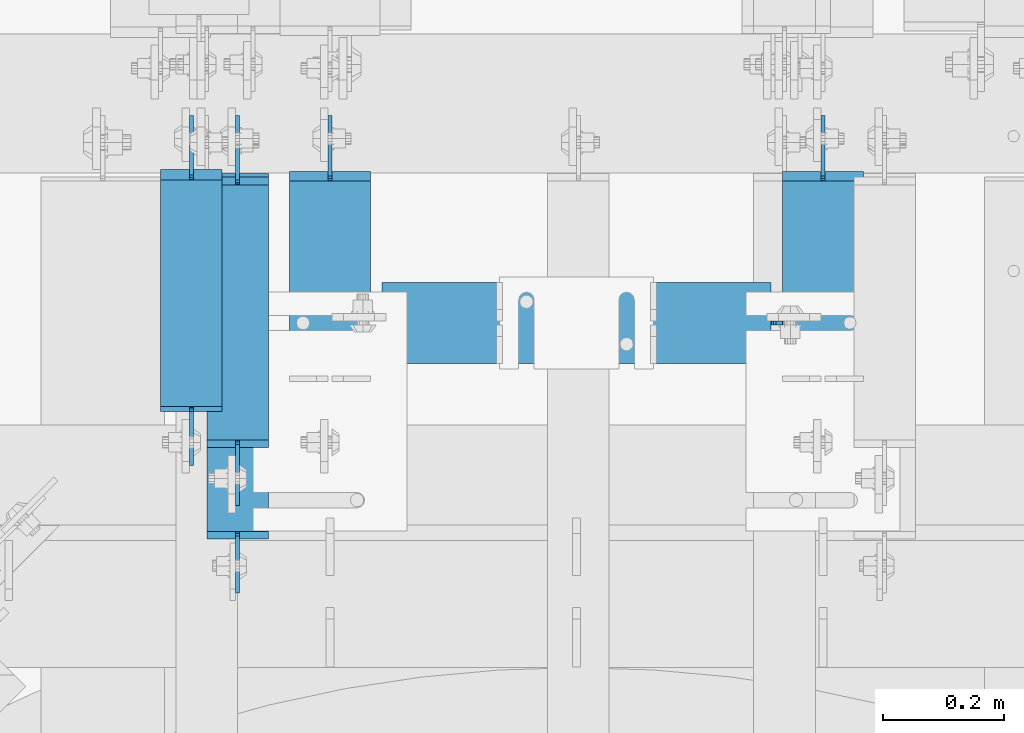
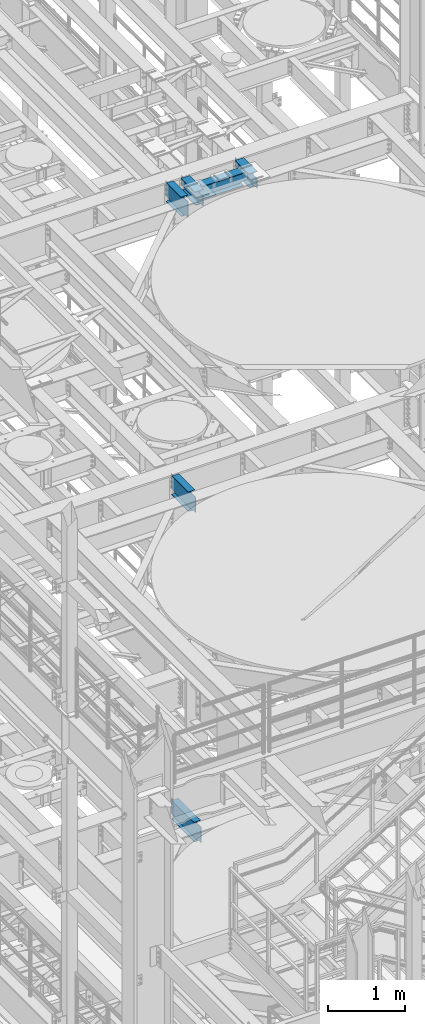
# One storey, part 1240 of 1876: 6 beams, 6 elements without a shape of their own.
"""IFC2X3 building model written with IfcOpenShell, lengths in millimetres."""

import ifcopenshell
import ifcopenshell.guid

model = None  # the IFC model being written
_history = None  # IfcOwnerHistory: only IFC2X3 demands one
_inside = {}  # id of a spatial element -> (the spatial element, [elements in it])
_under = {}  # id of a project, library or spatial element -> (it, [spatial elements below it])
_declared = {}  # id of a project -> (the project, [libraries it declares])
_typed = {}  # id of a type object -> (the type object, [elements of that type])
_made_of = {}  # id of a material, layer set ... -> (it, [elements and type objects made of it])


def new_model(schema):
    """Start an empty IFC model of exactly this schema.

    Asked for "IFC4X3", IfcOpenShell would pick the latest addendum, in which some entities
    have other attributes; the version numbers below select the first issue.
    IFC2X3 requires an IfcOwnerHistory on every rooted entity: one is made here for all.
    """
    global model, _history
    if schema == "IFC4X3":
        model = ifcopenshell.file(schema_version=(4, 3, 0, 0))
    else:
        model = ifcopenshell.file(schema=schema)
    _inside.clear()
    _under.clear()
    _declared.clear()
    _typed.clear()
    _made_of.clear()
    _history = None
    if model.schema == "IFC2X3":
        org = make("IfcOrganization", Name="unknown")
        user = make(
            "IfcPersonAndOrganization",
            ThePerson=make("IfcPerson", FamilyName="unknown"),
            TheOrganization=org,
        )
        app = make(
            "IfcApplication",
            ApplicationDeveloper=org,
            Version="unknown",
            ApplicationFullName="unknown",
            ApplicationIdentifier="unknown",
        )
        _history = make(
            "IfcOwnerHistory",
            OwningUser=user,
            OwningApplication=app,
            ChangeAction="ADDED",
            CreationDate=0,
        )
    return model


def make(cls, **values):
    """One entity of the class cls with the attributes given. An attribute that is None is left unset."""
    return model.create_entity(
        cls, **{name: value for name, value in values.items() if value is not None}
    )


def rooted(cls, **values):
    """An entity with a GlobalId (a new one), such as an element, a storey or a relation."""
    return make(cls, GlobalId=ifcopenshell.guid.new(), OwnerHistory=_history, **values)


def si_unit(unit_type, name, prefix=None):
    """IfcSIUnit, for example si_unit("LENGTHUNIT", "METRE", prefix="MILLI")."""
    return make("IfcSIUnit", UnitType=unit_type, Prefix=prefix, Name=name)


def assignment(units):
    """IfcUnitAssignment: the units of a project."""
    return None if units is None else make("IfcUnitAssignment", Units=units)


def point(xyz):
    """IfcCartesianPoint."""
    return None if xyz is None else make("IfcCartesianPoint", Coordinates=xyz)


def direction(xyz):
    """IfcDirection."""
    return None if xyz is None else make("IfcDirection", DirectionRatios=xyz)


def frame(location, z_axis=None, x_axis=None):
    """IfcAxis2Placement3D, a coordinate frame: its origin and axes. An axis left out is left unset."""
    return make(
        "IfcAxis2Placement3D",
        Location=point(location),
        Axis=direction(z_axis),
        RefDirection=direction(x_axis),
    )


def origin_with_axes():
    """The frame at (0, 0, 0) with the z axis (0, 0, 1) and the x axis (1, 0, 0) written out."""
    return frame((0.0, 0.0, 0.0), z_axis=(0.0, 0.0, 1.0), x_axis=(1.0, 0.0, 0.0))


def place(relative_to, where):
    """IfcLocalPlacement: puts the frame where relative to a parent placement (None: the world)."""
    return make(
        "IfcLocalPlacement", PlacementRelTo=relative_to, RelativePlacement=where
    )


def context(
    kind, dimensions, precision=None, world=None, true_north=None, identifier=None
):
    """IfcGeometricRepresentationContext, for example the 3D "Model" context."""
    return make(
        "IfcGeometricRepresentationContext",
        ContextIdentifier=identifier,
        ContextType=kind,
        CoordinateSpaceDimension=dimensions,
        Precision=precision,
        WorldCoordinateSystem=world,
        TrueNorth=true_north,
    )


def subcontext(parent, identifier, kind, view, scale=None):
    """IfcGeometricRepresentationSubContext, for example "Body" below "Model"."""
    return make(
        "IfcGeometricRepresentationSubContext",
        ContextIdentifier=identifier,
        ContextType=kind,
        ParentContext=parent,
        TargetScale=scale,
        TargetView=view,
    )


def project(units=None, contexts=None):
    """IfcProject with its units and contexts."""
    return rooted(
        "IfcProject",
        Name="project",
        RepresentationContexts=contexts,
        UnitsInContext=assignment(units),
    )


def spatial(cls, under=None, at=None, **own):
    """A site, building, storey or space (cls), placed at a placement, below another one or the project."""
    s = rooted(cls, ObjectPlacement=at, **own)
    if under is not None:
        _under.setdefault(under.id(), (under, []))[1].append(s)
    return s


def faces_of(points, faces, orient=None, outer=None):
    """IfcFace entities. A face is a list of loops; a loop is a list of indices into points, from 0.

    orient and outer hold one flag for each loop. By default every Orientation is true, the
    first loop of a face is its IfcFaceOuterBound and the others are IfcFaceBound.
    """
    made = []
    for i, loops in enumerate(faces):
        bounds = []
        for j, loop in enumerate(loops):
            is_outer = j == 0 if outer is None else outer[i][j]
            bounds.append(
                make(
                    "IfcFaceOuterBound" if is_outer else "IfcFaceBound",
                    Bound=make("IfcPolyLoop", Polygon=[points[k] for k in loop]),
                    Orientation=True if orient is None else orient[i][j],
                )
            )
        made.append(make("IfcFace", Bounds=bounds))
    return made


def faceted_brep(points, faces, orient=None, outer=None, voids=None):
    """IfcFacetedBrep: a solid bounded by flat faces; with voids (closed shells), ...WithVoids."""
    shared = [point(p) for p in points]
    hull = make("IfcClosedShell", CfsFaces=faces_of(shared, faces, orient, outer))
    if voids is None:
        return make("IfcFacetedBrep", Outer=hull)
    return make(
        "IfcFacetedBrepWithVoids",
        Outer=hull,
        Voids=[
            make(cls, CfsFaces=faces_of(shared, fs, o, b)) for cls, fs, o, b in voids
        ],
    )


def shape(context_of_items, identifier, shape_type, items):
    """IfcShapeRepresentation: the items that make up one representation, for example the "Body"."""
    return make(
        "IfcShapeRepresentation",
        ContextOfItems=context_of_items,
        RepresentationIdentifier=identifier,
        RepresentationType=shape_type,
        Items=items,
    )


def material(Name=None, Category=None):
    """IfcMaterial."""
    return make("IfcMaterial", Name=Name, Category=Category)


def made_of(thing, what):
    """Note that an element or type object is made of a material, layer set ...; save() writes the relation."""
    if what is not None:
        _made_of.setdefault(what.id(), (what, []))[1].append(thing)
    return thing


def type_object(cls, material=None, **own):
    """A type object (cls), such as IfcWallType, which elements share."""
    return made_of(rooted(cls, **own), material)


def element(
    cls,
    number,
    at=None,
    inside=None,
    cuts=None,
    type_object=None,
    material=None,
    context=None,
    identifier="Body",
    shape_type=None,
    held_by="IfcProductDefinitionShape",
    body=None,
    shapes=None,
    **own,
):
    """One element of the class cls, such as IfcWall. Its Tag is "e" and its number.

    at: its placement. inside: the storey or other place that contains it. cuts: it is an
    opening in that element (IfcRelVoidsElement). A single representation is given by context,
    identifier, shape_type and body (its items); several are given by shapes. held_by: the class
    of the entity that holds the representations. save() writes the other relations.
    """
    e = rooted(cls, Tag="e%d" % number, ObjectPlacement=at, **own)
    if body is not None:
        shapes = [shape(context, identifier, shape_type, body)]
    if shapes is not None:
        e.Representation = make(held_by, Representations=shapes)
    if inside is not None:
        _inside.setdefault(inside.id(), (inside, []))[1].append(e)
    if cuts is not None:
        rooted(
            "IfcRelVoidsElement", RelatingBuildingElement=cuts, RelatedOpeningElement=e
        )
    if type_object is not None:
        _typed.setdefault(type_object.id(), (type_object, []))[1].append(e)
    return made_of(e, material)


def aggregate(whole, parts):
    """IfcRelAggregates: a whole, such as a stair, and the parts it consists of."""
    return rooted("IfcRelAggregates", RelatingObject=whole, RelatedObjects=parts)


def save(model, path):
    """Write the relations noted so far, then the file.

    IfcRelAggregates (storeys below a building ...), IfcRelContainedInSpatialStructure (elements
    in a storey), IfcRelDefinesByType, IfcRelAssociatesMaterial and IfcRelDeclares: one each for
    every whole, place, type object, material and project.
    """
    for whole, parts in _under.values():
        aggregate(whole, parts)
    for where, things in _inside.values():
        rooted(
            "IfcRelContainedInSpatialStructure",
            RelatedElements=things,
            RelatingStructure=where,
        )
    for kind, things in _typed.values():
        rooted("IfcRelDefinesByType", RelatedObjects=things, RelatingType=kind)
    for what, things in _made_of.values():
        rooted("IfcRelAssociatesMaterial", RelatedObjects=things, RelatingMaterial=what)
    for by, libraries in _declared.values():
        rooted("IfcRelDeclares", RelatingContext=by, RelatedDefinitions=libraries)
    model.write(path)


model = new_model("IFC2X3")

# Units and contexts
model_context = context("Model", 3, precision=1e-05, world=origin_with_axes())
body_context = subcontext(model_context, "Body", "Model", "MODEL_VIEW")
ifc_project = project(units=[si_unit("LENGTHUNIT", "METRE", prefix="MILLI"), si_unit("AREAUNIT", "SQUARE_METRE"), si_unit("VOLUMEUNIT", "CUBIC_METRE"), si_unit("MASSUNIT", "GRAM", prefix="KILO"), si_unit("TIMEUNIT", "SECOND"), si_unit("PLANEANGLEUNIT", "RADIAN"), si_unit("SOLIDANGLEUNIT", "STERADIAN"), si_unit("THERMODYNAMICTEMPERATUREUNIT", "DEGREE_CELSIUS"), si_unit("LUMINOUSINTENSITYUNIT", "LUMEN")], contexts=[model_context])

# Site, building, storey
site_placement = place(None, origin_with_axes())
site = spatial("IfcSite", under=ifc_project, at=site_placement, CompositionType="ELEMENT")
building_placement = place(site_placement, origin_with_axes())
building = spatial("IfcBuilding", under=site, at=building_placement, Name="Undefined", CompositionType="ELEMENT")
storey_placement = place(building_placement, origin_with_axes())
storey = spatial("IfcBuildingStorey", under=building, at=storey_placement, Name="Undefined", CompositionType="ELEMENT", Elevation=0.0)

# Assembly, beam
assembly_1_placement = place(storey_placement, origin_with_axes())
assembly_1 = element("IfcElementAssembly", 1, at=assembly_1_placement, inside=storey, Name="BEAM", AssemblyPlace="NOTDEFINED", PredefinedType="RIGID_FRAME")
ifc_material = material(Name="STEEL/A992")
beam_type_1 = type_object("IfcBeamType", Name="W12X16", PredefinedType="NOTDEFINED")
beam_1_placement = place(assembly_1_placement, frame((3784.6, 895.349999999455, 17830.8), z_axis=(0.0, 0.0, 1.0), x_axis=(0.0, 1.0, 0.0)))
beam_1 = element("IfcBeam", 2, at=beam_1_placement, type_object=beam_type_1, material=ifc_material, Name="BEAM", ObjectType="W12X16", context=body_context, shape_type="Brep", body=[
    faceted_brep([(31.7499999999999, -3.17500000000018, -127.0), (31.7499999999999, 3.17500000000018, -127.0), (107.950000190735, 3.17500002282031, -127.0), (107.950000190735, -3.17500000000018, -127.0), (112.810079708781, 3.17500002297356, -127.966729922588), (112.810079708781, -3.17500000000018, -127.966729922588), (116.930256176934, 3.17500002339284, -130.719743823065), (116.930256176934, -3.17500000000018, -130.719743823065), (119.683270077412, 3.17500002401403, -134.839920291219), (119.683270077412, -3.17500000000018, -134.839920291219), (120.65, -3.17500000000018, -139.699999809265), (120.65, 3.17500002474299, -139.699999809265), (120.65, 3.17500009242758, -146.049999999999), (120.65, 50.8000000000002, -146.049999999999), (120.65, 50.8000000000002, -152.400000000001), (120.65, -50.8000000000002, -152.400000000001), (120.65, -50.8000000000002, -146.049999999999), (120.65, -3.17500000000018, -146.049999999999), (502.443750000545, 50.8000000000002, 146.049999999999), (502.443750000545, 3.17500000000018, 146.049999999999), (128.5875, 3.17500000000018, 146.049999999999), (128.5875, 50.8000000000002, 146.049999999999), (115.887500190735, -3.17500000000018, 120.650000000001), (115.887500190735, 3.17499998659878, 120.650000000001), (31.7499999999999, 3.17500000000018, 120.650000000001), (31.7499999999999, -3.17500000000018, 120.650000000001), (120.747579708781, -3.17500000000018, 121.616729922589), (120.747579708781, 3.17499998645872, 121.616729922589), (124.867756176934, -3.17500000000018, 124.369743823067), (124.867756176934, 3.17499998605672, 124.369743823067), (127.620770077412, -3.17500000000018, 128.48992029122), (127.620770077412, 3.17499998545327, 128.48992029122), (128.5875, -3.17500000000018, 133.349999809267), (128.5875, 3.17499998474068, 133.349999809267), (502.443750000545, -50.8000000000002, 152.400000000001), (502.443750000545, 50.8000000000002, 152.400000000001), (128.5875, 50.8000000000002, 152.400000000001), (128.5875, -50.8000000000002, 152.400000000001), (502.443750000545, -50.8000000000002, 146.049999999999), (128.5875, -50.8000000000002, 146.049999999999), (502.443750000545, -3.17500000000018, 146.049999999999), (128.5875, -3.17500000000018, 146.049999999999), (502.443750000545, -3.17500000000018, 120.64999980927), (502.443750000545, 3.17500000000018, 120.64999980927), (503.410479923132, -3.17500000000018, 115.789920291223), (503.410479923132, 3.17500000000018, 115.789920291223), (506.163493823611, -3.17500000000018, 111.669743823069), (506.163493823611, 3.17500000000018, 111.669743823069), (510.283670291764, -3.17500000000018, 108.916729922592), (510.283670291764, 3.17500000000018, 108.916729922592), (515.14374980981, -3.17500000000018, 107.950000000004), (515.14374980981, 3.17500000000018, 107.950000000004), (608.806250000545, -3.17500000000018, 107.950000000004), (608.806250000545, 3.17500000000018, 107.950000000004), (608.806250000545, -3.17500000000018, -126.999999999996), (608.806250000545, 3.17500000000018, -126.999999999996), (532.60624980981, -3.17500000000018, -126.999999999996), (532.60624980981, 3.17500000000018, -126.999999999996), (527.746170291764, -3.17500000000018, -127.966729922584), (527.746170291764, 3.17500000000018, -127.966729922584), (523.625993823611, -3.17500000000018, -130.719743823061), (523.625993823611, 3.17500000000018, -130.719743823061), (520.872979923132, -3.17500000000018, -134.839920291215), (520.872979923132, 3.17500000000018, -134.839920291215), (519.906250000545, -3.17500000000018, -139.699999809261), (519.906250000545, 3.17500000000018, -139.699999809261), (519.906250000544, -3.17500000000018, -146.049999999999), (519.906250000544, -50.8000000000002, -146.049999999999), (519.906250000544, -50.8000000000002, -152.400000000001), (519.906250000544, 50.8000000000002, -152.400000000001), (519.906250000544, 50.8000000000002, -146.049999999999), (519.906250000544, 3.17500000000018, -146.049999999999)], [[[0, 1, 2, 3]], [[3, 2, 4, 5]], [[5, 4, 6, 7]], [[7, 6, 8, 9]], [[10, 11, 12, 13, 14, 15, 16, 17]], [[9, 8, 11, 10]], [[18, 19, 20, 21]], [[22, 23, 24, 25]], [[26, 27, 23, 22]], [[28, 29, 27, 26]], [[30, 31, 29, 28]], [[32, 33, 31, 30]], [[34, 35, 36, 37]], [[38, 34, 37, 39]], [[40, 38, 39, 41]], [[37, 36, 21, 20, 33, 32, 41, 39]], [[35, 18, 21, 36]], [[34, 38, 40, 42, 43, 19, 18, 35]], [[44, 45, 43, 42]], [[46, 47, 45, 44]], [[48, 49, 47, 46]], [[50, 51, 49, 48]], [[52, 53, 51, 50]], [[53, 52, 54, 55]], [[54, 56, 57, 55]], [[58, 59, 57, 56]], [[60, 61, 59, 58]], [[62, 63, 61, 60]], [[64, 65, 63, 62]], [[66, 67, 68, 69, 70, 71, 65, 64]], [[67, 66, 17, 16]], [[68, 67, 16, 15]], [[69, 68, 15, 14]], [[70, 69, 14, 13]], [[71, 70, 13, 12]], [[6, 4, 2, 1, 24, 23, 27, 29, 31, 33, 20, 19, 43, 45, 47, 49, 51, 53, 55, 57, 59, 61, 63, 65, 71, 12, 11, 8]], [[25, 24, 1, 0]], [[66, 64, 62, 60, 58, 56, 54, 52, 50, 48, 46, 44, 42, 40, 41, 32, 30, 28, 26, 22, 25, 0, 3, 5, 7, 9, 10, 17]]]),
])
aggregate(assembly_1, [beam_1])

assembly_2_placement = place(storey_placement, origin_with_axes())
assembly_2 = element("IfcElementAssembly", 3, at=assembly_2_placement, inside=storey, Name="BEAM", AssemblyPlace="NOTDEFINED", PredefinedType="RIGID_FRAME")
beam_2_placement = place(assembly_2_placement, frame((3860.8, 762.0, 13157.2), z_axis=(0.0, 0.0, 1.0), x_axis=(0.0, 1.0, 0.0)))
beam_2 = element("IfcBeam", 4, at=beam_2_placement, type_object=beam_type_1, material=ifc_material, Name="BEAM", ObjectType="W12X16", context=body_context, shape_type="Brep", body=[
    faceted_brep([(99.2187500000005, -3.17500000000018, -127.0), (99.2187500000005, 3.17500000000018, -127.0), (181.768750190735, 3.17500000000018, -127.0), (181.768750190735, -3.17500000000018, -127.0), (186.628829708781, 3.17500000000018, -127.966729922588), (186.628829708781, -3.17500000000018, -127.966729922588), (190.749006176934, 3.17500000000018, -130.719743823065), (190.749006176934, -3.17500000000018, -130.719743823065), (193.502020077412, 3.17500000000018, -134.839920291219), (193.502020077412, -3.17500000000018, -134.839920291219), (194.46875, -3.17500000000018, -139.699999809265), (194.46875, 3.17500000000018, -139.699999809265), (194.46875, 3.17500000000018, -146.049999999999), (194.46875, 50.8000000000002, -146.049999999999), (194.46875, 50.8000000000002, -152.4), (194.46875, -50.8000000000002, -152.4), (194.46875, -50.8000000000002, -146.049999999999), (194.46875, -3.17500000000018, -146.049999999999), (627.85625, 50.8000000000002, 146.049999999999), (627.85625, 3.17500000000018, 146.049999999999), (207.16875, 3.17500000000018, 146.049999999999), (207.16875, 50.8000000000002, 146.049999999999), (194.468750190735, -3.17500000000018, 114.299999999999), (194.468750190735, 3.17500000000018, 114.299999999999), (99.2187500000005, 3.17500000000018, 114.299999999999), (99.2187500000005, -3.17500000000018, 114.299999999999), (199.328829708781, -3.17500000000018, 115.266729922587), (199.328829708781, 3.17500000000018, 115.266729922587), (203.449006176934, -3.17500000000018, 118.019743823064), (203.449006176934, 3.17500000000018, 118.019743823064), (206.202020077412, -3.17500000000018, 122.139920291218), (206.202020077412, 3.17500000000018, 122.139920291218), (207.16875, -3.17500000000018, 126.999999809264), (207.16875, 3.17500000000018, 126.999999809264), (627.85625, -50.8000000000002, 152.4), (627.85625, 50.8000000000002, 152.4), (207.16875, 50.8000000000002, 152.4), (207.16875, -50.8000000000002, 152.4), (627.85625, -50.8000000000002, 146.049999999999), (207.16875, -50.8000000000002, 146.049999999999), (627.85625, -3.17500000000018, 146.049999999999), (207.16875, -3.17500000000018, 146.049999999999), (627.85625, -3.17500000000018, 126.999999809264), (627.85625, 3.17500000000018, 126.999999809264), (628.822979922588, -3.17500000000018, 122.139920291218), (628.822979922588, 3.17500000000018, 122.139920291218), (631.575993823066, -3.17500000000018, 118.019743823064), (631.575993823066, 3.17500000000018, 118.019743823064), (635.696170291219, -3.17500000000018, 115.266729922587), (635.696170291219, 3.17500000000018, 115.266729922587), (640.556249809265, -3.17500000000018, 114.299999999999), (640.556249809265, 3.17500000000018, 114.299999999999), (742.15625, -3.17500000000018, 114.299999999999), (742.15625, 3.17500000000018, 114.299999999999), (742.15625, -3.17500000000018, -126.999999999996), (742.15625, 3.17500000000018, -126.999999999996), (653.256249809265, -3.17500000000018, -127.0), (653.256249809265, 3.17500000000018, -127.0), (648.39617029122, -3.17500000000018, -127.966729922588), (648.39617029122, 3.17500000000018, -127.966729922588), (644.275993823066, -3.17500000000018, -130.719743823065), (644.275993823066, 3.17500000000018, -130.719743823065), (641.522979922588, -3.17500000000018, -134.839920291219), (641.522979922588, 3.17500000000018, -134.839920291219), (640.55625, -3.17500000000018, -139.699999809265), (640.55625, 3.17500000000018, -139.699999809265), (640.55625, -3.17500000000018, -146.049999999999), (640.55625, -50.8000000000002, -146.049999999999), (640.55625, -50.8000000000002, -152.4), (640.55625, 50.8000000000002, -152.4), (640.55625, 50.8000000000002, -146.049999999999), (640.55625, 3.17500000000018, -146.049999999999)], [[[0, 1, 2, 3]], [[3, 2, 4, 5]], [[5, 4, 6, 7]], [[7, 6, 8, 9]], [[10, 11, 12, 13, 14, 15, 16, 17]], [[9, 8, 11, 10]], [[18, 19, 20, 21]], [[22, 23, 24, 25]], [[26, 27, 23, 22]], [[28, 29, 27, 26]], [[30, 31, 29, 28]], [[32, 33, 31, 30]], [[34, 35, 36, 37]], [[38, 34, 37, 39]], [[40, 38, 39, 41]], [[37, 36, 21, 20, 33, 32, 41, 39]], [[35, 18, 21, 36]], [[34, 38, 40, 42, 43, 19, 18, 35]], [[44, 45, 43, 42]], [[46, 47, 45, 44]], [[48, 49, 47, 46]], [[50, 51, 49, 48]], [[52, 53, 51, 50]], [[53, 52, 54, 55]], [[54, 56, 57, 55]], [[58, 59, 57, 56]], [[60, 61, 59, 58]], [[62, 63, 61, 60]], [[64, 65, 63, 62]], [[66, 67, 68, 69, 70, 71, 65, 64]], [[67, 66, 17, 16]], [[68, 67, 16, 15]], [[69, 68, 15, 14]], [[70, 69, 14, 13]], [[71, 70, 13, 12]], [[6, 4, 2, 1, 24, 23, 27, 29, 31, 33, 20, 19, 43, 45, 47, 49, 51, 53, 55, 57, 59, 61, 63, 65, 71, 12, 11, 8]], [[25, 24, 1, 0]], [[66, 64, 62, 60, 58, 56, 54, 52, 50, 48, 46, 44, 42, 40, 41, 32, 30, 28, 26, 22, 25, 0, 3, 5, 7, 9, 10, 17]]]),
])
aggregate(assembly_2, [beam_2])

assembly_3_placement = place(storey_placement, origin_with_axes())
assembly_3 = element("IfcElementAssembly", 5, at=assembly_3_placement, inside=storey, Name="BEAM", AssemblyPlace="NOTDEFINED", PredefinedType="RIGID_FRAME")
beam_3_placement = place(assembly_3_placement, frame((3860.8, 863.6, 8001.0), z_axis=(0.0, 0.0, 1.0), x_axis=(0.0, 1.0, 0.0)))
beam_3 = element("IfcBeam", 6, at=beam_3_placement, type_object=beam_type_1, material=ifc_material, Name="BEAM", ObjectType="W12X16", context=body_context, shape_type="Brep", body=[
    faceted_brep([(-146.645312, -3.17500000000018, -126.999999999999), (-146.645312, 3.17500000000018, -126.999999999999), (-70.4453118092653, 3.17500000000018, -126.999999999999), (-70.4453118092653, -3.17500000000018, -126.999999999999), (-65.5852322912197, 3.17500000000018, -127.966729922587), (-65.5852322912197, -3.17500000000018, -127.966729922587), (-61.465055823066, 3.17500000000018, -130.719743823065), (-61.465055823066, -3.17500000000018, -130.719743823065), (-58.712041922588, 3.17500000000018, -134.839920291219), (-58.712041922588, -3.17500000000018, -134.839920291219), (-57.7453120000001, -3.17500000000018, -139.699999809264), (-57.7453120000001, 3.17500000000018, -139.699999809264), (-57.7453120000001, 3.17500000000018, -146.05), (-57.7453120000001, 50.8000000000002, -146.05), (-57.7453120000001, 50.8000000000002, -152.4), (-57.7453120000001, -50.8000000000002, -152.4), (-57.7453120000001, -50.8000000000002, -146.05), (-57.7453120000001, -3.17500000000018, -146.05), (532.60625, 50.8000000000002, 146.05), (532.60625, 3.17500000000018, 146.05), (-45.0453120000001, 3.17500000000018, 146.05), (-45.0453120000001, 50.8000000000002, 146.05), (-57.7453118092652, -3.17500000000018, 120.650000000001), (-57.7453118092652, 3.17500000000018, 120.650000000001), (-146.645312, 3.17500000000018, 120.650000000001), (-146.645312, -3.17500000000018, 120.650000000001), (-52.8852322912196, -3.17500000000018, 121.616729922588), (-52.8852322912196, 3.17500000000018, 121.616729922588), (-48.7650558230659, -3.17500000000018, 124.369743823067), (-48.7650558230659, 3.17500000000018, 124.369743823067), (-46.012041922588, -3.17500000000018, 128.48992029122), (-46.012041922588, 3.17500000000018, 128.48992029122), (-45.0453120000001, -3.17500000000018, 133.349999809266), (-45.0453120000001, 3.17500000000018, 133.349999809266), (532.60625, -50.8000000000002, 152.4), (532.60625, 50.8000000000002, 152.4), (-45.0453120000001, 50.8000000000002, 152.4), (-45.0453120000001, -50.8000000000002, 152.4), (532.60625, -50.8000000000002, 146.05), (-45.0453120000001, -50.8000000000002, 146.05), (532.60625, -3.17500000000018, 146.05), (-45.0453120000001, -3.17500000000018, 146.05), (532.60625, -3.17500000000018, 126.999999809264), (532.60625, 3.17500000000018, 126.999999809264), (533.572979922587, -3.17500000000018, 122.139920291219), (533.572979922587, 3.17500000000018, 122.139920291219), (536.325993823065, -3.17500000000018, 118.019743823065), (536.325993823065, 3.17500000000018, 118.019743823065), (540.446170291219, -3.17500000000018, 115.266729922587), (540.446170291219, 3.17500000000018, 115.266729922587), (545.306249809265, -3.17500000000018, 114.299999999999), (545.306249809265, 3.17500000000018, 114.299999999999), (640.556249809265, -3.17500000000018, 114.299999999999), (640.556249809265, 3.17500000000018, 114.299999999999), (640.556249999999, -3.17500000000018, -127.000000000001), (640.556249999999, 3.17500000000018, -127.000000000001), (558.006249809265, -3.17500000000018, -127.000000000001), (558.006249809265, 3.17500000000018, -127.000000000001), (553.146170291219, -3.17500000000018, -127.966729922588), (553.146170291219, 3.17500000000018, -127.966729922588), (549.025993823066, -3.17500000000018, -130.719743823067), (549.025993823066, 3.17500000000018, -130.719743823067), (546.272979922587, -3.17500000000018, -134.839920291221), (546.272979922587, 3.17500000000018, -134.839920291221), (545.30625, -3.17500000000018, -139.699999809266), (545.30625, 3.17500000000018, -139.699999809266), (545.30625, -3.17500000000018, -146.05), (545.30625, -50.8000000000002, -146.05), (545.30625, -50.8000000000002, -152.4), (545.30625, 50.8000000000002, -152.4), (545.30625, 50.8000000000002, -146.05), (545.30625, 3.17500000000018, -146.05)], [[[0, 1, 2, 3]], [[3, 2, 4, 5]], [[5, 4, 6, 7]], [[7, 6, 8, 9]], [[10, 11, 12, 13, 14, 15, 16, 17]], [[9, 8, 11, 10]], [[18, 19, 20, 21]], [[22, 23, 24, 25]], [[26, 27, 23, 22]], [[28, 29, 27, 26]], [[30, 31, 29, 28]], [[32, 33, 31, 30]], [[34, 35, 36, 37]], [[38, 34, 37, 39]], [[40, 38, 39, 41]], [[37, 36, 21, 20, 33, 32, 41, 39]], [[35, 18, 21, 36]], [[34, 38, 40, 42, 43, 19, 18, 35]], [[44, 45, 43, 42]], [[46, 47, 45, 44]], [[48, 49, 47, 46]], [[50, 51, 49, 48]], [[52, 53, 51, 50]], [[53, 52, 54, 55]], [[54, 56, 57, 55]], [[58, 59, 57, 56]], [[60, 61, 59, 58]], [[62, 63, 61, 60]], [[64, 65, 63, 62]], [[66, 67, 68, 69, 70, 71, 65, 64]], [[67, 66, 17, 16]], [[68, 67, 16, 15]], [[69, 68, 15, 14]], [[70, 69, 14, 13]], [[71, 70, 13, 12]], [[6, 4, 2, 1, 24, 23, 27, 29, 31, 33, 20, 19, 43, 45, 47, 49, 51, 53, 55, 57, 59, 61, 63, 65, 71, 12, 11, 8]], [[25, 24, 1, 0]], [[66, 64, 62, 60, 58, 56, 54, 52, 50, 48, 46, 44, 42, 40, 41, 32, 30, 28, 26, 22, 25, 0, 3, 5, 7, 9, 10, 17]]]),
])
aggregate(assembly_3, [beam_3])

assembly_4_placement = place(storey_placement, origin_with_axes())
assembly_4 = element("IfcElementAssembly", 7, at=assembly_4_placement, inside=storey, Name="BEAM", AssemblyPlace="NOTDEFINED", PredefinedType="RIGID_FRAME")
beam_type_2 = type_object("IfcBeamType", Name="W8X18", PredefinedType="NOTDEFINED")
beam_4_placement = place(assembly_4_placement, frame((4013.20017785198, 1162.05030517578, 17880.0125), z_axis=(0.0, 0.0, 1.0), x_axis=(1.0, 0.0, 0.0)))
beam_4 = element("IfcBeam", 8, at=beam_4_placement, type_object=beam_type_2, material=ifc_material, Name="BEAM", ObjectType="W8X18", context=body_context, shape_type="Brep", body=[
    faceted_brep([(704.850000000001, -3.17499999999995, -95.25), (704.850000000001, -66.675, -95.25), (704.850000000001, -66.675, -103.1875), (704.850000000001, 66.675, -103.1875), (704.850000000001, 66.675, -95.25), (704.850000000001, 3.17499999999995, -95.25), (704.850000000001, 3.17499999999995, -90.4874998092637), (704.850000000001, -3.17499999999995, -90.4874998092637), (705.816729922589, 3.17499999999995, -85.6274202912173), (705.816729922589, -3.17499999999995, -85.6274202912173), (708.569743823067, 3.17499999999995, -81.5072438230636), (708.569743823067, -3.17499999999995, -81.5072438230636), (712.689920291221, 3.17499999999995, -78.7542299225861), (712.689920291221, -3.17499999999995, -78.7542299225861), (717.549999809266, 3.17499999999995, -77.7874999999985), (717.549999809266, -3.17499999999995, -77.7874999999985), (796.925, -3.17499999999995, -77.7874999999985), (796.925, 3.17499999999995, -77.7874999999985), (85.7250000000013, 66.675, 103.1875), (85.7250000000013, -66.675, 103.1875), (727.075000000001, -66.675, 103.1875), (727.075000000001, 66.675, 103.1875), (85.7250000000013, 66.675, 96.8374998092659), (85.7250000000013, -66.675, 96.8374998092659), (85.4092266547259, -66.675, 95.25), (727.390773345277, -66.675, 95.25), (727.075000000001, -66.675, 96.8374998092659), (727.075000000001, 66.675, 96.8374998092659), (85.4092266547259, 66.675, 95.25), (727.390773345277, 66.675, 95.25), (85.4092266547259, 3.17499999999995, 95.25), (727.390773345277, 3.17499999999995, 95.25), (107.950000000001, -3.17500000000018, -90.48749980926), (107.950000000001, 3.17500000000018, -90.48749980926), (107.950000000001, 3.17500000000018, -95.25), (107.950000000001, 66.6750000000002, -95.25), (107.950000000001, 66.6750000000002, -103.1875), (107.950000000001, -66.6750000000002, -103.1875), (107.950000000001, -66.6750000000002, -95.25), (107.950000000001, -3.17500000000018, -95.25), (106.983270077413, -3.17500000000018, -85.6274202912136), (106.983270077413, 3.17500000000018, -85.6274202912136), (104.230256176935, -3.17500000000018, -81.50724382306), (104.230256176935, 3.17500000000018, -81.50724382306), (100.110079708781, -3.17500000000018, -78.7542299225825), (100.110079708781, 3.17500000000018, -78.7542299225825), (95.2500001907356, -3.17500000000018, -77.7874999999949), (95.2500001907356, 3.17500000000018, -77.7874999999949), (15.875, -3.17500000000018, -77.7874999999949), (15.875, 3.17500000000018, -77.7874999999949), (15.875, -3.17500000000018, 84.1375000000044), (15.875, 3.17500000000018, 84.1375000000044), (73.0250001907361, -3.17499999999995, 84.1375000000007), (73.0250001907361, 3.17499999999995, 84.1375000000007), (77.8850797087816, -3.17499999999995, 85.1042299225883), (77.8850797087816, 3.17499999999995, 85.1042299225883), (82.0052561769353, -3.17499999999995, 87.8572438230658), (82.0052561769353, 3.17499999999995, 87.8572438230658), (84.7582700774137, -3.17499999999995, 91.9774202912195), (84.7582700774137, 3.17499999999995, 91.9774202912195), (85.4092266547259, -3.17499999999995, 95.25), (727.390773345277, -3.17499999999995, 95.25), (728.041729922588, -3.17499999999995, 91.9774202912195), (728.041729922588, 3.17499999999995, 91.9774202912195), (730.794743823067, -3.17499999999995, 87.8572438230658), (730.794743823067, 3.17499999999995, 87.8572438230658), (734.91492029122, -3.17499999999995, 85.1042299225883), (734.91492029122, 3.17499999999995, 85.1042299225883), (739.774999809266, -3.17499999999995, 84.1375000000007), (739.774999809266, 3.17499999999995, 84.1375000000007), (796.925, -3.17499999999995, 84.1375000000007), (796.925, 3.17499999999995, 84.1375000000007)], [[[0, 1, 2, 3, 4, 5, 6, 7]], [[7, 6, 8, 9]], [[9, 8, 10, 11]], [[11, 10, 12, 13]], [[13, 12, 14, 15]], [[16, 15, 14, 17]], [[18, 19, 20, 21]], [[19, 18, 22, 23]], [[20, 19, 23, 24, 25, 26]], [[20, 26, 27, 21]], [[28, 22, 18, 21, 27, 29]], [[30, 28, 29, 31]], [[32, 33, 34, 35, 36, 37, 38, 39]], [[40, 41, 33, 32]], [[42, 43, 41, 40]], [[44, 45, 43, 42]], [[46, 47, 45, 44]], [[48, 49, 47, 46]], [[50, 51, 49, 48]], [[52, 53, 51, 50]], [[54, 55, 53, 52]], [[56, 57, 55, 54]], [[58, 59, 57, 56]], [[23, 22, 28, 30, 59, 58, 60, 24]], [[24, 60, 61, 25]], [[62, 63, 31, 29, 27, 26, 25, 61]], [[64, 65, 63, 62]], [[66, 67, 65, 64]], [[68, 69, 67, 66]], [[70, 71, 69, 68]], [[71, 70, 16, 17]], [[12, 10, 8, 6, 5, 34, 33, 41, 43, 45, 47, 49, 51, 53, 55, 57, 59, 30, 31, 63, 65, 67, 69, 71, 17, 14]], [[35, 34, 5, 4]], [[36, 35, 4, 3]], [[37, 36, 3, 2]], [[38, 37, 2, 1]], [[39, 38, 1, 0]], [[70, 68, 66, 64, 62, 61, 60, 58, 56, 54, 52, 50, 48, 46, 44, 42, 40, 32, 39, 0, 7, 9, 11, 13, 15, 16]]]),
])
aggregate(assembly_4, [beam_4])

assembly_5_placement = place(storey_placement, origin_with_axes())
assembly_5 = element("IfcElementAssembly", 9, at=assembly_5_placement, inside=storey, Name="BEAM", AssemblyPlace="NOTDEFINED", PredefinedType="RIGID_FRAME")
beam_5_placement = place(assembly_5_placement, frame((4826.00017785198, 911.224999999456, 17880.0125), z_axis=(0.0, 0.0, 1.0), x_axis=(0.0, 1.0, 0.0)))
beam_5 = element("IfcBeam", 10, at=beam_5_placement, type_object=beam_type_2, material=ifc_material, Name="BEAM", ObjectType="W8X18", context=body_context, shape_type="Brep", body=[
    faceted_brep([(500.856250000543, -3.17500000000018, -95.25), (500.856250000543, -66.6750000000002, -95.25), (500.856250000543, -66.6750000000002, -103.1875), (500.856250000543, 66.6750000000002, -103.1875), (500.856250000543, 66.6750000000002, -95.25), (500.856250000543, 3.17500000000018, -95.25), (500.856250000543, 3.17500000000018, -93.6624998092593), (500.856250000543, -3.17500000000018, -93.6624998092593), (501.822979923131, 3.17500000000018, -88.8024202912129), (501.822979923131, -3.17500000000018, -88.8024202912129), (504.575993823609, 3.17500000000018, -84.6822438230593), (504.575993823609, -3.17500000000018, -84.6822438230593), (508.696170291763, 3.17500000000018, -81.9292299225817), (508.696170291763, -3.17500000000018, -81.9292299225817), (513.556249809809, 3.17500000000018, -80.9624999999942), (513.556249809809, -3.17500000000018, -80.9624999999942), (592.931250000543, -3.17500000000018, -80.9624999999942), (592.931250000543, 3.17500000000018, -80.9624999999942), (123.824999999999, 3.17500000000018, 95.25), (123.824999999999, 66.6750000000002, 95.25), (484.981250000543, 66.6750000000002, 95.25), (484.981250000543, 3.17500000000018, 95.25), (107.949999999999, -3.17500000000018, -93.6624998092702), (107.949999999999, 3.17500000000018, -93.6624998092702), (107.950000000001, 3.17500000000018, -95.25), (107.950000000001, 66.6750000000002, -95.25), (107.950000000001, 66.6750000000002, -103.1875), (107.950000000001, -66.6750000000002, -103.1875), (107.950000000001, -66.6750000000002, -95.25), (107.950000000001, -3.17500000000018, -95.25), (106.983270077411, -3.17500000000018, -88.8024202912238), (106.983270077411, 3.17500000000018, -88.8024202912238), (104.230256176933, -3.17500000000018, -84.6822438230702), (104.230256176933, 3.17500000000018, -84.6822438230702), (100.110079708779, -3.17500000000018, -81.9292299225926), (100.110079708779, 3.17500000000018, -81.9292299225926), (95.2500001907338, -3.17500000000018, -80.9625000000051), (95.2500001907338, 3.17500000000018, -80.9625000000051), (15.8749999999989, -3.17500000000018, -80.9625000000051), (15.8749999999989, 3.17500000000018, -80.9625000000051), (15.875, -3.17500000000018, 71.4375), (15.875, 3.17500000000018, 71.4375), (111.125000190734, -3.17500000000018, 71.4374999999964), (111.125000190734, 3.17500000000018, 71.4374999999964), (115.985079708779, -3.17500000000018, 72.4042299225839), (115.985079708779, 3.17500000000018, 72.4042299225839), (120.105256176933, -3.17500000000018, 75.1572438230614), (120.105256176933, 3.17500000000018, 75.1572438230614), (122.858270077411, -3.17500000000018, 79.2774202912151), (122.858270077411, 3.17500000000018, 79.2774202912151), (123.824999999999, -3.17500000000018, 84.1374998092615), (123.824999999999, 3.17500000000018, 84.1374998092615), (123.824999999999, -66.6750000000002, 103.1875), (123.824999999999, 66.6750000000002, 103.1875), (123.824999999999, -3.17500000000018, 95.25), (123.824999999999, -66.6750000000002, 95.25), (484.981250000543, -3.17500000000018, 95.25), (484.981250000543, -66.6750000000002, 95.25), (484.981250000543, -66.6750000000002, 103.1875), (484.981250000543, 66.6750000000002, 103.1875), (484.981250000543, -3.17500000000018, 77.7874998092702), (484.981250000543, 3.17500000000018, 77.7874998092702), (485.947979923131, -3.17500000000018, 72.9274202912238), (485.947979923131, 3.17500000000018, 72.9274202912238), (488.700993823609, -3.17500000000018, 68.8072438230702), (488.700993823609, 3.17500000000018, 68.8072438230702), (492.821170291763, -3.17500000000018, 66.0542299225926), (492.821170291763, 3.17500000000018, 66.0542299225926), (497.681249809809, -3.17500000000018, 65.0875000000051), (497.681249809809, 3.17500000000018, 65.0875000000051), (592.931250000543, -3.17500000000018, 65.0875000000051), (592.931250000543, 3.17500000000018, 65.0875000000051)], [[[0, 1, 2, 3, 4, 5, 6, 7]], [[7, 6, 8, 9]], [[9, 8, 10, 11]], [[11, 10, 12, 13]], [[13, 12, 14, 15]], [[16, 15, 14, 17]], [[18, 19, 20, 21]], [[22, 23, 24, 25, 26, 27, 28, 29]], [[30, 31, 23, 22]], [[32, 33, 31, 30]], [[34, 35, 33, 32]], [[36, 37, 35, 34]], [[38, 39, 37, 36]], [[40, 41, 39, 38]], [[42, 43, 41, 40]], [[44, 45, 43, 42]], [[46, 47, 45, 44]], [[48, 49, 47, 46]], [[50, 51, 49, 48]], [[52, 53, 19, 18, 51, 50, 54, 55]], [[55, 54, 56, 57]], [[52, 55, 57, 58]], [[53, 52, 58, 59]], [[19, 53, 59, 20]], [[58, 57, 56, 60, 61, 21, 20, 59]], [[62, 63, 61, 60]], [[64, 65, 63, 62]], [[66, 67, 65, 64]], [[68, 69, 67, 66]], [[70, 71, 69, 68]], [[71, 70, 16, 17]], [[12, 10, 8, 6, 5, 24, 23, 31, 33, 35, 37, 39, 41, 43, 45, 47, 49, 51, 18, 21, 61, 63, 65, 67, 69, 71, 17, 14]], [[25, 24, 5, 4]], [[26, 25, 4, 3]], [[27, 26, 3, 2]], [[28, 27, 2, 1]], [[29, 28, 1, 0]], [[70, 68, 66, 64, 62, 60, 56, 54, 50, 48, 46, 44, 42, 40, 38, 36, 34, 32, 30, 22, 29, 0, 7, 9, 11, 13, 15, 16]]]),
])
aggregate(assembly_5, [beam_5])

assembly_6_placement = place(storey_placement, origin_with_axes())
assembly_6 = element("IfcElementAssembly", 11, at=assembly_6_placement, inside=storey, Name="BEAM", AssemblyPlace="NOTDEFINED", PredefinedType="RIGID_FRAME")
beam_6_placement = place(assembly_6_placement, frame((4013.20017785198, 911.224999999456, 17880.0125), z_axis=(0.0, 0.0, 1.0), x_axis=(0.0, 1.0, 0.0)))
beam_6 = element("IfcBeam", 12, at=beam_6_placement, type_object=beam_type_2, material=ifc_material, Name="BEAM", ObjectType="W8X18", context=body_context, shape_type="Brep", body=[
    faceted_brep([(500.856250000543, -3.17500000000018, -95.25), (500.856250000543, -66.6750000000002, -95.25), (500.856250000543, -66.6750000000002, -103.1875), (500.856250000543, 66.6750000000002, -103.1875), (500.856250000543, 66.6750000000002, -95.25), (500.856250000543, 3.17500000000018, -95.25), (500.856250000543, 3.17500000000018, -93.6624998092593), (500.856250000543, -3.17500000000018, -93.6624998092593), (501.822979923131, 3.17500000000018, -88.8024202912129), (501.822979923131, -3.17500000000018, -88.8024202912129), (504.575993823609, 3.17500000000018, -84.6822438230593), (504.575993823609, -3.17500000000018, -84.6822438230593), (508.696170291763, 3.17500000000018, -81.9292299225817), (508.696170291763, -3.17500000000018, -81.9292299225817), (513.556249809809, 3.17500000000018, -80.9624999999942), (513.556249809809, -3.17500000000018, -80.9624999999942), (592.931250000543, -3.17500000000018, -80.9624999999942), (592.931250000543, 3.17500000000018, -80.9624999999942), (123.824999999999, 3.17500000000018, 95.25), (123.824999999999, 66.6750000000002, 95.25), (484.981250000543, 66.6750000000002, 95.25), (484.981250000543, 3.17500000000018, 95.25), (107.949999999999, -3.17500000000018, -93.6624998092702), (107.949999999999, 3.17500000000018, -93.6624998092702), (107.950000000001, 3.17500000000018, -95.25), (107.950000000001, 66.6750000000002, -95.25), (107.950000000001, 66.6750000000002, -103.1875), (107.950000000001, -66.6750000000002, -103.1875), (107.950000000001, -66.6750000000002, -95.25), (107.950000000001, -3.17500000000018, -95.25), (106.983270077411, -3.17500000000018, -88.8024202912238), (106.983270077411, 3.17500000000018, -88.8024202912238), (104.230256176933, -3.17500000000018, -84.6822438230702), (104.230256176933, 3.17500000000018, -84.6822438230702), (100.110079708779, -3.17500000000018, -81.9292299225926), (100.110079708779, 3.17500000000018, -81.9292299225926), (95.2500001907338, -3.17500000000018, -80.9625000000051), (95.2500001907338, 3.17500000000018, -80.9625000000051), (15.8749999999989, -3.17500000000018, -80.9625000000051), (15.8749999999989, 3.17500000000018, -80.9625000000051), (15.875, -3.17500000000018, 71.4375), (15.875, 3.17500000000018, 71.4375), (111.125000190734, -3.17500000000018, 71.4374999999964), (111.125000190734, 3.17500000000018, 71.4374999999964), (115.985079708779, -3.17500000000018, 72.4042299225839), (115.985079708779, 3.17500000000018, 72.4042299225839), (120.105256176933, -3.17500000000018, 75.1572438230614), (120.105256176933, 3.17500000000018, 75.1572438230614), (122.858270077411, -3.17500000000018, 79.2774202912151), (122.858270077411, 3.17500000000018, 79.2774202912151), (123.824999999999, -3.17500000000018, 84.1374998092615), (123.824999999999, 3.17500000000018, 84.1374998092615), (123.824999999999, -66.6750000000002, 103.1875), (123.824999999999, 66.6750000000002, 103.1875), (123.824999999999, -3.17500000000018, 95.25), (123.824999999999, -66.6750000000002, 95.25), (484.981250000543, -3.17500000000018, 95.25), (484.981250000543, -66.6750000000002, 95.25), (484.981250000543, -66.6750000000002, 103.1875), (484.981250000543, 66.6750000000002, 103.1875), (484.981250000543, -3.17500000000018, 77.7874998092702), (484.981250000543, 3.17500000000018, 77.7874998092702), (485.947979923131, -3.17500000000018, 72.9274202912238), (485.947979923131, 3.17500000000018, 72.9274202912238), (488.700993823609, -3.17500000000018, 68.8072438230702), (488.700993823609, 3.17500000000018, 68.8072438230702), (492.821170291763, -3.17500000000018, 66.0542299225926), (492.821170291763, 3.17500000000018, 66.0542299225926), (497.681249809809, -3.17500000000018, 65.0875000000051), (497.681249809809, 3.17500000000018, 65.0875000000051), (592.931250000543, -3.17500000000018, 65.0875000000051), (592.931250000543, 3.17500000000018, 65.0875000000051)], [[[0, 1, 2, 3, 4, 5, 6, 7]], [[7, 6, 8, 9]], [[9, 8, 10, 11]], [[11, 10, 12, 13]], [[13, 12, 14, 15]], [[16, 15, 14, 17]], [[18, 19, 20, 21]], [[22, 23, 24, 25, 26, 27, 28, 29]], [[30, 31, 23, 22]], [[32, 33, 31, 30]], [[34, 35, 33, 32]], [[36, 37, 35, 34]], [[38, 39, 37, 36]], [[40, 41, 39, 38]], [[42, 43, 41, 40]], [[44, 45, 43, 42]], [[46, 47, 45, 44]], [[48, 49, 47, 46]], [[50, 51, 49, 48]], [[52, 53, 19, 18, 51, 50, 54, 55]], [[55, 54, 56, 57]], [[52, 55, 57, 58]], [[53, 52, 58, 59]], [[19, 53, 59, 20]], [[58, 57, 56, 60, 61, 21, 20, 59]], [[62, 63, 61, 60]], [[64, 65, 63, 62]], [[66, 67, 65, 64]], [[68, 69, 67, 66]], [[70, 71, 69, 68]], [[71, 70, 16, 17]], [[12, 10, 8, 6, 5, 24, 23, 31, 33, 35, 37, 39, 41, 43, 45, 47, 49, 51, 18, 21, 61, 63, 65, 67, 69, 71, 17, 14]], [[25, 24, 5, 4]], [[26, 25, 4, 3]], [[27, 26, 3, 2]], [[28, 27, 2, 1]], [[29, 28, 1, 0]], [[70, 68, 66, 64, 62, 60, 56, 54, 50, 48, 46, 44, 42, 40, 38, 36, 34, 32, 30, 22, 29, 0, 7, 9, 11, 13, 15, 16]]]),
])
aggregate(assembly_6, [beam_6])

save(model, "model.ifc")
